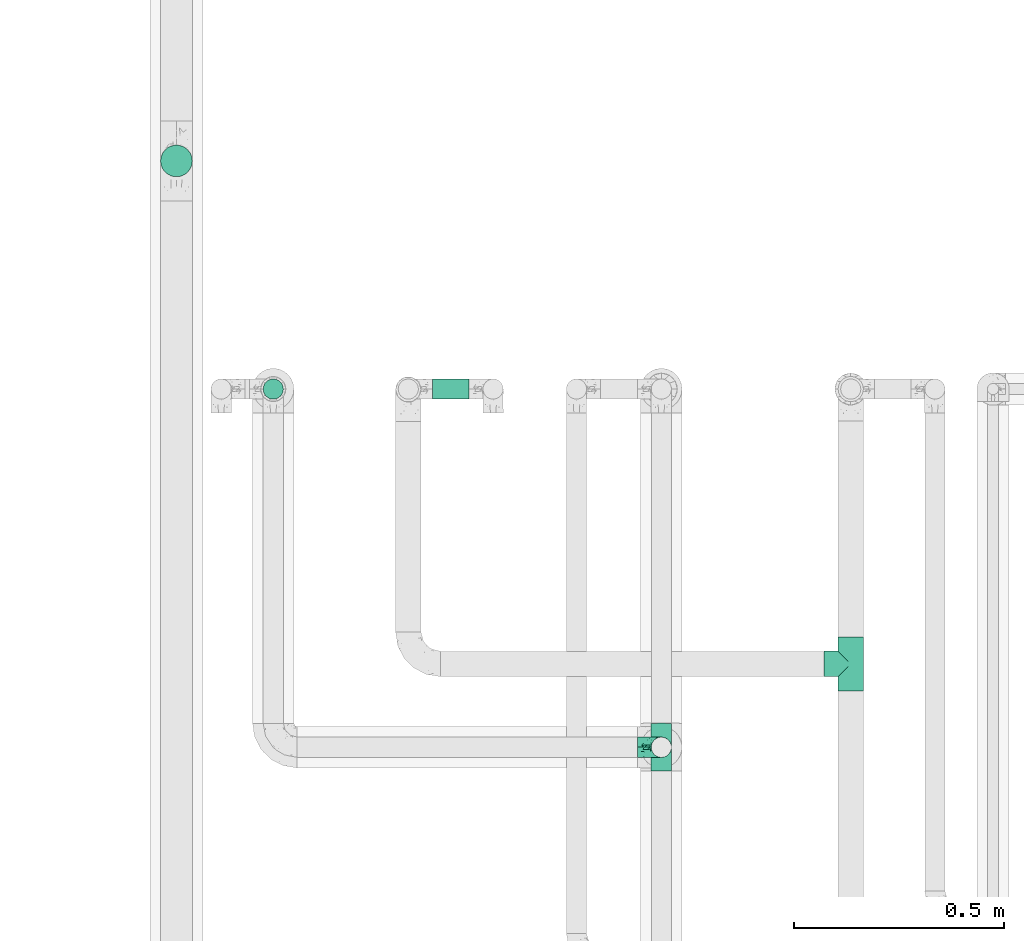
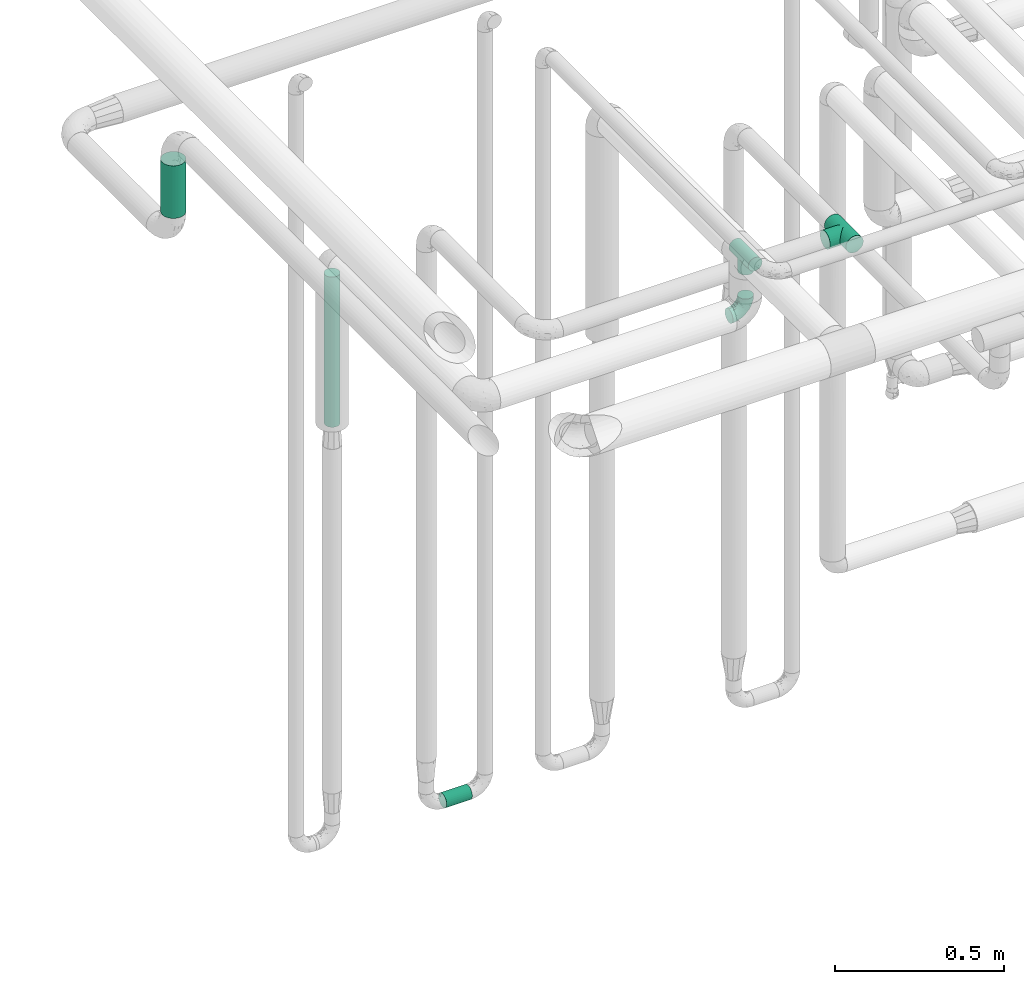
# One storey, part 696 of 827: 3 flow fittings, 3 flow segments.
"""IFC2X3 building model written with IfcOpenShell, lengths in millimetres."""

from ifc_helpers import new_model, entity, si_unit, converted_unit, derived_unit, direction, frame, origin, origin_2d_with_axis, place, context, subcontext, project, spatial, circle, extrude, faceted_brep, source, transform, mapped, material, type_object, type_shapes, element, save


model = new_model("IFC2X3")

# Units and contexts
model_context = context("Model", 3, precision=0.01, world=origin(), true_north=direction((6.12303176911189e-17, 1.0)))
body_context = subcontext(model_context, "Body", "Model", "MODEL_VIEW")
ifc_project = project(units=[si_unit("LENGTHUNIT", "METRE", prefix="MILLI"), si_unit("AREAUNIT", "SQUARE_METRE"), si_unit("VOLUMEUNIT", "CUBIC_METRE"), converted_unit("PLANEANGLEUNIT", "DEGREE", entity("IfcRatioMeasure", 0.0174532925199433), si_unit("PLANEANGLEUNIT", "RADIAN"), dimensions=[0, 0, 0, 0, 0, 0, 0]), si_unit("MASSUNIT", "GRAM", prefix="KILO"), derived_unit("MASSDENSITYUNIT", [(si_unit("MASSUNIT", "GRAM", prefix="KILO"), 1), (si_unit("LENGTHUNIT", "METRE"), -3)]), derived_unit("MOMENTOFINERTIAUNIT", [(si_unit("LENGTHUNIT", "METRE"), 4)]), si_unit("TIMEUNIT", "SECOND"), si_unit("FREQUENCYUNIT", "HERTZ"), si_unit("THERMODYNAMICTEMPERATUREUNIT", "DEGREE_CELSIUS"), derived_unit("THERMALTRANSMITTANCEUNIT", [(si_unit("MASSUNIT", "GRAM", prefix="KILO"), 1), (si_unit("THERMODYNAMICTEMPERATUREUNIT", "KELVIN"), -1), (si_unit("TIMEUNIT", "SECOND"), -3)]), derived_unit("VOLUMETRICFLOWRATEUNIT", [(si_unit("LENGTHUNIT", "METRE"), 3), (si_unit("TIMEUNIT", "SECOND"), -1)]), derived_unit("MASSFLOWRATEUNIT", [(si_unit("MASSUNIT", "GRAM", prefix="KILO"), 1), (si_unit("TIMEUNIT", "SECOND"), -1)]), derived_unit("ROTATIONALFREQUENCYUNIT", [(si_unit("TIMEUNIT", "SECOND"), -1)]), si_unit("ELECTRICCURRENTUNIT", "AMPERE"), si_unit("ELECTRICVOLTAGEUNIT", "VOLT"), si_unit("POWERUNIT", "WATT"), si_unit("FORCEUNIT", "NEWTON", prefix="KILO"), si_unit("ILLUMINANCEUNIT", "LUX"), si_unit("LUMINOUSFLUXUNIT", "LUMEN"), si_unit("LUMINOUSINTENSITYUNIT", "CANDELA"), derived_unit("USERDEFINED", [(si_unit("MASSUNIT", "GRAM", prefix="KILO"), -1), (si_unit("LENGTHUNIT", "METRE"), -2), (si_unit("TIMEUNIT", "SECOND"), 3), (si_unit("LUMINOUSFLUXUNIT", "LUMEN"), 1)]), derived_unit("LINEARVELOCITYUNIT", [(si_unit("LENGTHUNIT", "METRE"), 1), (si_unit("TIMEUNIT", "SECOND"), -1)]), si_unit("PRESSUREUNIT", "PASCAL"), derived_unit("USERDEFINED", [(si_unit("LENGTHUNIT", "METRE"), -2), (si_unit("MASSUNIT", "GRAM", prefix="KILO"), 1), (si_unit("TIMEUNIT", "SECOND"), -2)]), derived_unit("LINEARFORCEUNIT", [(si_unit("MASSUNIT", "GRAM", prefix="KILO"), 1), (si_unit("LENGTHUNIT", "METRE"), 1), (si_unit("TIMEUNIT", "SECOND"), -2), (si_unit("LENGTHUNIT", "METRE"), -1)]), derived_unit("PLANARFORCEUNIT", [(si_unit("MASSUNIT", "GRAM", prefix="KILO"), 1), (si_unit("LENGTHUNIT", "METRE"), 1), (si_unit("TIMEUNIT", "SECOND"), -2), (si_unit("LENGTHUNIT", "METRE"), -2)])], contexts=[model_context])

# Site, building, storey
site_placement = place(None, origin())
site = spatial("IfcSite", under=ifc_project, at=site_placement, CompositionType="ELEMENT")
building_placement = place(site_placement, origin())
building = spatial("IfcBuilding", under=site, at=building_placement, CompositionType="ELEMENT")
storey_placement = place(building_placement, frame((0.0, 0.0, 28200.0)))
storey = spatial("IfcBuildingStorey", under=building, at=storey_placement, Name="08", CompositionType="ELEMENT", Elevation=28200.0)

# Flow segments
pipe_segment_type = type_object("IfcPipeSegmentType", PredefinedType="NOTDEFINED")
flow_segment_1_placement = place(storey_placement, frame((51928.76, 18003.03, 2415.0)))
element("IfcFlowSegment", 1, at=flow_segment_1_placement, inside=storey, type_object=pipe_segment_type, context=body_context, shape_type="SweptSolid", body=[
    extrude(circle(Radius=37.75, at=origin_2d_with_axis()), frame((39.35, 39.35, 0.0)), (0.0, 0.0, 1.0), 190.000000000004),
])
flow_segment_2_placement = place(storey_placement, frame((52576.38, 17474.4, 374.4)))
element("IfcFlowSegment", 2, at=flow_segment_2_placement, inside=storey, type_object=pipe_segment_type, context=body_context, shape_type="SweptSolid", body=[
    extrude(circle(Radius=24.0, at=origin_2d_with_axis()), frame((0.0, 25.6, 25.6), z_axis=(1.0, 0.0, 0.0), x_axis=(0.0, 1.0, 0.0)), (0.0, 0.0, 1.0), 87.6742700000116),
])
flow_segment_3_placement = place(storey_placement, frame((52172.68, 17474.4, 1898.17)))
element("IfcFlowSegment", 3, at=flow_segment_3_placement, inside=storey, type_object=pipe_segment_type, context=body_context, shape_type="SweptSolid", body=[
    extrude(circle(Radius=24.0, at=origin_2d_with_axis()), frame((25.6, 25.6, 0.0)), (0.0, 0.0, 1.0), 543.000000000011),
])

# Flow fittings
ifc_material = material()
pipe_fitting_type_1 = type_object("IfcPipeFittingType", Name="ADSK_1", PredefinedType="NOTDEFINED", material=ifc_material)
shared_shape_1 = source(origin(), body_context, "Body", "Brep", [
    faceted_brep([(-57.0, 12.07, -20.91), (-57.0, 6.25, -23.33), (-57.0, 0.0, -24.15), (-57.0, -6.25, -23.33), (-57.0, -12.08, -20.91), (-57.0, -17.08, -17.08), (-57.0, -20.91, -12.08), (-57.0, -23.33, -6.25), (-57.0, -24.15, 0.0), (-57.0, -23.33, 6.25), (-57.0, -20.91, 12.07), (-57.0, -17.08, 17.08), (-57.0, -12.08, 20.91), (-57.0, -6.25, 23.33), (-57.0, 0.0, 24.15), (-57.0, 6.25, 23.33), (-57.0, 12.07, 20.91), (-57.0, 17.08, 17.08), (-57.0, 20.91, 12.07), (-57.0, 23.33, 6.25), (-57.0, 24.15, 0.0), (-57.0, 23.33, -6.25), (-57.0, 20.91, -12.08), (-57.0, 17.08, -17.08), (0.0, 57.0, -24.15), (-6.25, 57.0, -23.33), (-12.07, 57.0, -20.91), (-17.08, 57.0, -17.08), (-20.91, 57.0, -12.08), (-23.33, 57.0, -6.25), (-24.15, 57.0, 0.0), (-23.33, 57.0, 6.25), (-20.91, 57.0, 12.07), (-17.08, 57.0, 17.08), (-12.07, 57.0, 20.91), (-6.25, 57.0, 23.33), (0.0, 57.0, 24.15), (6.25, 57.0, 23.33), (12.08, 57.0, 20.91), (17.08, 57.0, 17.08), (20.91, 57.0, 12.07), (23.33, 57.0, 6.25), (24.15, 57.0, 0.0), (23.33, 57.0, -6.25), (20.91, 57.0, -12.08), (17.08, 57.0, -17.08), (12.08, 57.0, -20.91), (6.25, 57.0, -23.33), (14.9, 21.14, 6.17), (13.61, 24.64, 12.48), (6.23, 8.95, 8.98), (-41.47, -21.06, 0.0), (-41.92, -18.38, 13.72), (-24.64, -13.61, 12.48), (-37.37, -13.24, 18.15), (-6.8, -4.93, 8.18), (-21.76, -15.19, 6.22), (-12.78, -9.18, 0.0), (-37.73, -20.51, 7.75), (-7.38, 7.38, 20.24), (-23.37, -4.26, 20.42), (-11.9, -3.19, 15.86), (-42.14, -8.7, 21.82), (13.24, 37.37, 18.15), (9.33, 23.53, 16.85), (4.26, 23.37, 20.42), (2.77, 10.92, 15.55), (-29.46, 0.91, 23.52), (-44.13, 20.56, 15.69), (-39.25, 26.33, 10.88), (-49.02, 22.92, 9.96), (-34.58, 23.87, 17.15), (-15.8, 6.8, 22.81), (-8.67, 20.47, 23.88), (-18.12, 12.9, 24.08), (-48.29, 14.92, 19.65), (-44.06, -2.85, 23.78), (-9.23, 48.95, 22.58), (-3.78, 42.74, 24.07), (-40.34, 4.26, 24.09), (-44.02, 26.14, 5.46), (-44.04, 9.88, 22.74), (-4.95, 16.87, 22.52), (-2.75, 1.43, 12.5), (-25.48, 40.98, 10.71), (20.51, 37.73, 7.75), (18.38, 41.92, 13.72), (8.7, 42.14, 21.82), (-25.95, -17.97, 0.0), (2.85, 44.06, 23.78), (21.06, 41.47, 0.0), (17.97, 25.95, 0.0), (-24.04, -9.27, 17.13), (-33.26, 33.26, 5.86), (-28.55, 40.57, 0.0), (-40.57, 28.55, 0.0), (-25.29, 47.19, 4.06), (-27.01, 31.1, 16.77), (-15.7, 43.95, 19.9), (-20.27, 45.22, 15.61), (-30.53, 31.98, 12.64), (-11.28, 38.33, 22.92), (-9.97, 27.88, 24.09), (-20.15, 30.26, 21.25), (-31.25, 11.75, 23.64), (-28.75, 7.23, 24.15), (-29.53, 18.06, 22.27), (-28.44, 24.21, 20.02), (-37.55, 17.7, 20.26), (-15.88, 29.25, 22.99), (-20.82, 20.82, 23.44), (-0.91, 29.46, 23.52), (-13.5, -7.67, 12.04), (1.49, 1.56, 5.16), (8.86, 10.35, 4.59), (0.38, -0.38, 0.0), (9.18, 12.78, 0.0), (-37.37, -13.24, -18.15), (8.86, 10.35, -4.59), (-45.22, 20.27, -15.61), (-43.95, 15.7, -19.9), (-38.33, 11.28, -22.92), (-48.95, 9.23, -22.58), (-47.19, 25.29, -4.06), (-33.26, 33.26, -5.86), (18.38, 41.92, -13.72), (-30.26, 20.15, -21.25), (2.85, 44.06, -23.78), (-4.26, 40.34, -24.09), (-40.98, 25.48, -10.71), (-41.92, -18.38, -13.72), (9.25, 23.5, -16.92), (4.26, 23.37, -20.42), (13.24, 37.37, -18.15), (-37.73, -20.51, -7.75), (-11.75, 31.25, -23.64), (-7.23, 28.75, -24.15), (-12.9, 18.12, -24.08), (8.7, 42.14, -21.82), (-44.06, -2.85, -23.78), (-6.8, 15.8, -22.81), (-20.47, 8.67, -23.88), (-24.64, -13.61, -12.48), (-42.74, 3.78, -24.07), (-18.06, 29.53, -22.27), (-24.21, 28.44, -20.02), (-27.88, 9.97, -24.09), (-31.1, 27.01, -16.77), (-26.14, 44.02, -5.46), (14.9, 21.14, -6.17), (20.51, 37.73, -7.75), (-9.88, 44.04, -22.74), (-20.56, 44.13, -15.69), (-21.76, -15.19, -6.22), (-13.5, -7.67, -12.04), (-24.14, -9.76, -16.74), (-11.9, -3.19, -15.86), (-14.92, 48.29, -19.65), (-23.37, -4.26, -20.42), (-0.91, 29.46, -23.52), (-26.33, 39.25, -10.88), (-23.87, 34.58, -17.15), (-42.14, -8.7, -21.82), (-22.92, 49.02, -9.96), (13.61, 24.64, -12.48), (-31.98, 30.53, -12.64), (-16.87, 4.95, -22.52), (-17.7, 37.55, -20.26), (-29.25, 15.88, -22.99), (-20.82, 20.82, -23.44), (-29.46, 0.91, -23.52), (-7.38, 7.38, -20.24), (2.77, 10.92, -15.55), (6.23, 8.95, -8.98), (-6.8, -4.93, -8.18), (-2.81, 1.41, -12.54), (1.49, 1.56, -5.16)], [[[0, 1, 2, 3, 4, 5, 6, 7, 8, 9, 10, 11, 12, 13, 14, 15, 16, 17, 18, 19, 20, 21, 22, 23]], [[24, 25, 26, 27, 28, 29, 30, 31, 32, 33, 34, 35, 36, 37, 38, 39, 40, 41, 42, 43, 44, 45, 46, 47]], [[48, 49, 50]], [[9, 8, 51]], [[52, 53, 54]], [[55, 56, 57]], [[10, 58, 52]], [[9, 58, 10]], [[59, 60, 61]], [[54, 12, 11]], [[54, 62, 12]], [[63, 39, 38]], [[64, 65, 66]], [[62, 60, 67]], [[68, 69, 70]], [[71, 69, 68]], [[72, 73, 74]], [[16, 75, 17]], [[13, 76, 14]], [[35, 77, 78]], [[14, 79, 15]], [[17, 68, 18]], [[14, 76, 79]], [[20, 19, 80]], [[70, 19, 18]], [[81, 15, 79]], [[15, 81, 16]], [[73, 72, 82]], [[66, 83, 50]], [[32, 31, 84]], [[85, 86, 49]], [[63, 87, 65]], [[56, 58, 88]], [[36, 89, 37]], [[85, 41, 40]], [[36, 35, 78]], [[90, 41, 85]], [[40, 39, 86]], [[12, 62, 13]], [[86, 85, 40]], [[48, 85, 49]], [[85, 91, 90]], [[87, 38, 37]], [[92, 60, 54]], [[80, 69, 93]], [[93, 94, 95]], [[10, 52, 11]], [[94, 96, 30]], [[97, 98, 99]], [[80, 93, 95]], [[100, 97, 84]], [[99, 98, 33]], [[101, 102, 78]], [[103, 101, 98]], [[96, 31, 30]], [[77, 98, 101]], [[77, 35, 34]], [[34, 33, 98]], [[9, 51, 58]], [[87, 63, 38]], [[104, 105, 74]], [[106, 103, 107]], [[106, 81, 104]], [[75, 68, 17]], [[108, 107, 71]], [[33, 32, 99]], [[109, 103, 110]], [[101, 109, 102]], [[89, 78, 111]], [[53, 52, 58]], [[54, 11, 52]], [[60, 62, 54]], [[88, 58, 51]], [[76, 62, 67]], [[53, 112, 92]], [[60, 59, 72]], [[39, 63, 86]], [[49, 86, 63]], [[89, 87, 37]], [[42, 41, 90]], [[111, 82, 65]], [[111, 65, 87]], [[65, 59, 66]], [[104, 81, 79]], [[75, 81, 108]], [[32, 84, 99]], [[97, 99, 84]], [[98, 97, 103]], [[106, 107, 108]], [[74, 102, 110]], [[111, 78, 102]], [[74, 110, 104]], [[74, 67, 72]], [[61, 92, 112]], [[66, 59, 61]], [[56, 53, 58]], [[66, 50, 49]], [[61, 112, 83]], [[66, 49, 64]], [[78, 89, 36]], [[87, 89, 111]], [[62, 76, 13]], [[79, 76, 67]], [[100, 93, 69]], [[96, 93, 84]], [[55, 113, 50]], [[113, 114, 50]], [[104, 79, 105]], [[106, 104, 110]], [[20, 80, 95]], [[85, 48, 91]], [[115, 114, 113]], [[116, 91, 48]], [[70, 80, 19]], [[93, 96, 94]], [[84, 31, 96]], [[103, 106, 110]], [[81, 106, 108]], [[103, 97, 107]], [[71, 107, 97]], [[71, 97, 100]], [[108, 71, 68]], [[79, 67, 105]], [[67, 74, 105]], [[115, 113, 57]], [[112, 56, 55]], [[56, 88, 57]], [[60, 72, 67]], [[82, 72, 59]], [[65, 82, 59]], [[82, 111, 73]], [[111, 102, 73]], [[102, 74, 73]], [[81, 75, 16]], [[68, 75, 108]], [[68, 70, 18]], [[80, 70, 69]], [[98, 77, 34]], [[78, 77, 101]], [[93, 100, 84]], [[71, 100, 69]], [[102, 109, 110]], [[101, 103, 109]], [[53, 92, 54]], [[61, 60, 92]], [[56, 112, 53]], [[83, 112, 55]], [[50, 83, 55]], [[61, 83, 66]], [[49, 63, 64]], [[65, 64, 63]], [[57, 113, 55]], [[114, 115, 116]], [[116, 48, 114]], [[48, 50, 114]], [[117, 5, 4]], [[116, 115, 118]], [[119, 120, 23]], [[121, 122, 120]], [[95, 123, 20]], [[0, 23, 120]], [[124, 95, 94]], [[125, 45, 44]], [[121, 120, 126]], [[24, 127, 128]], [[22, 21, 129]], [[0, 122, 1]], [[5, 117, 130]], [[131, 132, 133]], [[134, 88, 51]], [[135, 136, 137]], [[6, 5, 130]], [[46, 138, 47]], [[139, 3, 2]], [[140, 141, 137]], [[6, 134, 7]], [[134, 130, 142]], [[143, 2, 1]], [[144, 126, 145]], [[121, 146, 143]], [[147, 120, 119]], [[94, 148, 124]], [[149, 150, 91]], [[30, 29, 148]], [[151, 25, 128]], [[27, 152, 28]], [[134, 153, 88]], [[154, 155, 156]], [[27, 26, 157]], [[151, 26, 25]], [[155, 158, 156]], [[24, 47, 127]], [[1, 122, 143]], [[138, 132, 159]], [[160, 152, 161]], [[24, 128, 25]], [[46, 133, 138]], [[162, 117, 4]], [[148, 160, 124]], [[152, 160, 163]], [[154, 142, 155]], [[45, 125, 133]], [[133, 46, 45]], [[125, 164, 133]], [[51, 7, 134]], [[42, 90, 43]], [[165, 147, 129]], [[153, 134, 142]], [[43, 150, 44]], [[162, 4, 3]], [[141, 140, 166]], [[117, 162, 158]], [[163, 29, 28]], [[43, 90, 150]], [[123, 21, 20]], [[144, 151, 135]], [[157, 152, 27]], [[167, 145, 161]], [[23, 22, 119]], [[168, 126, 169]], [[121, 168, 146]], [[139, 143, 170]], [[142, 130, 117]], [[8, 7, 51]], [[134, 6, 130]], [[139, 162, 3]], [[170, 166, 158]], [[170, 158, 162]], [[158, 171, 156]], [[44, 150, 125]], [[91, 150, 90]], [[164, 125, 150]], [[132, 138, 133]], [[127, 138, 159]], [[131, 164, 172]], [[132, 171, 140]], [[135, 151, 128]], [[157, 151, 167]], [[22, 129, 119]], [[147, 119, 129]], [[120, 147, 126]], [[144, 145, 167]], [[137, 146, 169]], [[170, 143, 146]], [[137, 169, 135]], [[137, 159, 140]], [[171, 172, 156]], [[173, 174, 175]], [[156, 175, 154]], [[174, 57, 153]], [[132, 172, 171]], [[172, 164, 173]], [[143, 139, 2]], [[162, 139, 170]], [[138, 127, 47]], [[128, 127, 159]], [[165, 124, 160]], [[123, 124, 129]], [[149, 173, 164]], [[176, 174, 173]], [[135, 128, 136]], [[144, 135, 169]], [[150, 149, 164]], [[176, 118, 115]], [[149, 91, 116]], [[30, 148, 94]], [[163, 148, 29]], [[124, 123, 95]], [[129, 21, 123]], [[126, 144, 169]], [[151, 144, 167]], [[126, 147, 145]], [[161, 145, 147]], [[161, 147, 165]], [[167, 161, 152]], [[128, 159, 136]], [[159, 137, 136]], [[154, 153, 142]], [[132, 140, 159]], [[174, 176, 57]], [[57, 88, 153]], [[166, 140, 171]], [[158, 166, 171]], [[166, 170, 141]], [[170, 146, 141]], [[146, 137, 141]], [[151, 157, 26]], [[152, 157, 167]], [[152, 163, 28]], [[148, 163, 160]], [[120, 122, 0]], [[143, 122, 121]], [[124, 165, 129]], [[161, 165, 160]], [[146, 168, 169]], [[121, 126, 168]], [[142, 117, 155]], [[158, 155, 117]], [[175, 156, 172]], [[153, 154, 174]], [[173, 175, 172]], [[174, 154, 175]], [[164, 131, 133]], [[172, 132, 131]], [[176, 173, 118]], [[57, 176, 115]], [[173, 149, 118]], [[149, 116, 118]]]),
])
type_shapes(pipe_fitting_type_1, [shared_shape_1])
flow_fitting_1_placement = place(storey_placement, frame((53121.06, 16648.39, 2498.17), z_axis=(0.0, 0.999999852624976, 0.000542908855839149), x_axis=(0.0, 0.000542908855839149, -0.999999852624976)))
element("IfcFlowFitting", 4, at=flow_fitting_1_placement, inside=storey, type_object=pipe_fitting_type_1, material=ifc_material, Name="ADSK_1", ObjectType="ADSK_1", context=body_context, shape_type="MappedRepresentation", body=[
    mapped(shared_shape_1, transform((0.0, 0.0, 0.0), scale=1.0)),
])
pipe_fitting_type_2 = type_object("IfcPipeFittingType", Name="ADSK_1", PredefinedType="NOTDEFINED", material=ifc_material)
shared_shape_2 = source(origin(), body_context, "Body", "Brep", [
    faceted_brep([(-57.0, 12.07, -20.91), (-57.0, 6.25, -23.33), (-57.0, 0.0, -24.15), (-57.0, -6.25, -23.33), (-57.0, -12.08, -20.91), (-57.0, -17.08, -17.08), (-57.0, -20.91, -12.08), (-57.0, -23.33, -6.25), (-57.0, -24.15, 0.0), (-57.0, -23.33, 6.25), (-57.0, -20.91, 12.07), (-57.0, -17.08, 17.08), (-57.0, -12.08, 20.91), (-57.0, -6.25, 23.33), (-57.0, 0.0, 24.15), (-57.0, 6.25, 23.33), (-57.0, 12.07, 20.91), (-57.0, 17.08, 17.08), (-57.0, 20.91, 12.07), (-57.0, 23.33, 6.25), (-57.0, 24.15, 0.0), (-57.0, 23.33, -6.25), (-57.0, 20.91, -12.08), (-57.0, 17.08, -17.08), (57.0, 0.0, -24.15), (57.0, 6.25, -23.33), (57.0, 12.07, -20.91), (57.0, 17.08, -17.08), (57.0, 20.91, -12.08), (57.0, 23.33, -6.25), (57.0, 24.15, 0.0), (57.0, 23.33, 6.25), (57.0, 20.91, 12.07), (57.0, 17.08, 17.08), (57.0, 12.07, 20.91), (57.0, 6.25, 23.33), (57.0, 0.0, 24.15), (57.0, -6.25, 23.33), (57.0, -12.08, 20.91), (57.0, -17.08, 17.08), (57.0, -20.91, 12.07), (57.0, -23.33, 6.25), (57.0, -24.15, 0.0), (57.0, -23.33, -6.25), (57.0, -20.91, -12.08), (57.0, -17.08, -17.08), (57.0, -12.08, -20.91), (57.0, -6.25, -23.33), (23.27, -23.27, 6.45), (24.15, -24.15, 0.0), (-24.15, -24.15, 0.0), (20.9, -20.9, 12.1), (13.54, -13.54, 20.0), (17.52, -17.52, 16.62), (-23.27, -23.27, 6.45), (-20.9, -20.9, 12.1), (-17.52, -17.52, 16.62), (-13.54, -13.54, 20.0), (-9.19, -9.19, 22.33), (9.19, -9.19, 22.33), (4.64, -4.64, 23.7), (0.0, 0.0, 24.15), (-4.64, -4.64, 23.7), (4.64, -4.64, -23.7), (0.0, 0.0, -24.15), (-4.64, -4.64, -23.7), (-9.19, -9.19, -22.33), (9.19, -9.19, -22.33), (13.54, -13.54, -20.0), (17.52, -17.52, -16.62), (20.9, -20.9, -12.1), (23.27, -23.27, -6.45), (-13.54, -13.54, -20.0), (-17.52, -17.52, -16.62), (-23.27, -23.27, -6.45), (-20.9, -20.9, -12.1), (0.0, -57.0, -24.15), (6.25, -57.0, -23.33), (12.08, -57.0, -20.91), (17.08, -57.0, -17.08), (20.91, -57.0, -12.08), (23.33, -57.0, -6.25), (24.15, -57.0, 0.0), (23.33, -57.0, 6.25), (20.91, -57.0, 12.07), (17.08, -57.0, 17.08), (12.08, -57.0, 20.91), (6.25, -57.0, 23.33), (0.0, -57.0, 24.15), (-6.25, -57.0, 23.33), (-12.07, -57.0, 20.91), (-17.08, -57.0, 17.08), (-20.91, -57.0, 12.07), (-23.33, -57.0, 6.25), (-24.15, -57.0, 0.0), (-23.33, -57.0, -6.25), (-20.91, -57.0, -12.08), (-17.08, -57.0, -17.08), (-12.07, -57.0, -20.91), (-6.25, -57.0, -23.33)], [[[0, 1, 2, 3, 4, 5, 6, 7, 8, 9, 10, 11, 12, 13, 14, 15, 16, 17, 18, 19, 20, 21, 22, 23]], [[24, 25, 26, 27, 28, 29, 30, 31, 32, 33, 34, 35, 36, 37, 38, 39, 40, 41, 42, 43, 44, 45, 46, 47]], [[41, 40, 48]], [[42, 41, 49]], [[50, 9, 8]], [[49, 41, 48]], [[40, 51, 48]], [[39, 38, 52]], [[51, 40, 53]], [[52, 53, 39]], [[53, 40, 39]], [[50, 54, 9]], [[9, 54, 10]], [[54, 55, 10]], [[56, 57, 11]], [[11, 10, 56]], [[11, 57, 12]], [[56, 10, 55]], [[12, 57, 58]], [[52, 38, 59]], [[60, 36, 61]], [[62, 61, 14]], [[59, 37, 60]], [[37, 59, 38]], [[60, 37, 36]], [[61, 36, 35, 15, 14]], [[32, 31, 19, 18]], [[17, 16, 34, 33]], [[18, 17, 33, 32]], [[35, 34, 16, 15]], [[20, 19, 31, 30]], [[62, 13, 58]], [[13, 62, 14]], [[58, 13, 12]], [[27, 23, 22, 28]], [[22, 21, 29, 28]], [[0, 23, 27, 26]], [[20, 30, 29, 21]], [[24, 47, 63]], [[24, 64, 2, 1, 25]], [[64, 24, 63]], [[2, 64, 65]], [[26, 25, 1, 0]], [[65, 66, 3]], [[2, 65, 3]], [[66, 4, 3]], [[63, 47, 67]], [[46, 45, 68]], [[69, 68, 45]], [[44, 70, 69]], [[69, 45, 44]], [[46, 68, 67]], [[43, 42, 49]], [[7, 50, 8]], [[43, 71, 44]], [[71, 43, 49]], [[44, 71, 70]], [[72, 4, 66]], [[72, 5, 4]], [[5, 72, 73]], [[5, 73, 6]], [[74, 50, 7]], [[75, 74, 6]], [[74, 7, 6]], [[75, 6, 73]], [[46, 67, 47]], [[76, 77, 78, 79, 80, 81, 82, 83, 84, 85, 86, 87, 88, 89, 90, 91, 92, 93, 94, 95, 96, 97, 98, 99]], [[50, 94, 93]], [[54, 50, 93]], [[91, 90, 57]], [[56, 92, 91]], [[54, 93, 92]], [[58, 90, 89]], [[55, 54, 92]], [[56, 55, 92]], [[58, 57, 90]], [[88, 61, 62]], [[58, 89, 62]], [[56, 91, 57]], [[62, 89, 88]], [[60, 88, 87]], [[86, 59, 87]], [[84, 83, 48]], [[53, 85, 84]], [[52, 86, 85]], [[49, 83, 82]], [[59, 60, 87]], [[52, 59, 86]], [[49, 48, 83]], [[51, 53, 84]], [[48, 51, 84]], [[52, 85, 53]], [[88, 60, 61]], [[82, 81, 49]], [[71, 49, 81]], [[69, 80, 79]], [[79, 78, 68]], [[71, 81, 80]], [[67, 78, 77]], [[70, 71, 80]], [[69, 70, 80]], [[67, 68, 78]], [[76, 64, 63]], [[67, 77, 63]], [[69, 79, 68]], [[63, 77, 76]], [[65, 76, 99]], [[98, 66, 99]], [[96, 95, 74]], [[73, 97, 96]], [[72, 98, 97]], [[50, 95, 94]], [[66, 65, 99]], [[72, 66, 98]], [[50, 74, 95]], [[75, 73, 96]], [[74, 75, 96]], [[72, 97, 73]], [[76, 65, 64]]]),
])
type_shapes(pipe_fitting_type_2, [shared_shape_2])
flow_fitting_2_placement = place(storey_placement, frame((53121.06, 16648.39, 2699.3), z_axis=(-1.0, 0.0, 0.0), x_axis=(0.0, -0.999999057686602, 0.00137281677840057)))
element("IfcFlowFitting", 5, at=flow_fitting_2_placement, inside=storey, type_object=pipe_fitting_type_2, material=ifc_material, Name="ADSK_1", ObjectType="ADSK_1", context=body_context, shape_type="MappedRepresentation", body=[
    mapped(shared_shape_2, transform((0.0, 0.0, 0.0), scale=1.0)),
])
pipe_fitting_type_3 = type_object("IfcPipeFittingType", Name="ADSK_1", PredefinedType="NOTDEFINED", material=ifc_material)
shared_shape_3 = source(origin(), body_context, "Body", "Brep", [
    faceted_brep([(-64.0, 15.07, -26.11), (-64.0, 7.8, -29.12), (-64.0, 0.0, -30.15), (-64.0, -7.8, -29.12), (-64.0, -15.08, -26.11), (-64.0, -21.32, -21.32), (-64.0, -26.11, -15.08), (-64.0, -29.12, -7.8), (-64.0, -30.15, 0.0), (-64.0, -29.12, 7.8), (-64.0, -26.11, 15.07), (-64.0, -21.32, 21.32), (-64.0, -15.08, 26.11), (-64.0, -7.8, 29.12), (-64.0, 0.0, 30.15), (-64.0, 7.8, 29.12), (-64.0, 15.07, 26.11), (-64.0, 21.32, 21.32), (-64.0, 26.11, 15.07), (-64.0, 29.12, 7.8), (-64.0, 30.15, 0.0), (-64.0, 29.12, -7.8), (-64.0, 26.11, -15.08), (-64.0, 21.32, -21.32), (64.0, 0.0, -30.15), (64.0, 7.8, -29.12), (64.0, 15.07, -26.11), (64.0, 21.32, -21.32), (64.0, 26.11, -15.08), (64.0, 29.12, -7.8), (64.0, 30.15, 0.0), (64.0, 29.12, 7.8), (64.0, 26.11, 15.07), (64.0, 21.32, 21.32), (64.0, 15.07, 26.11), (64.0, 7.8, 29.12), (64.0, 0.0, 30.15), (64.0, -7.8, 29.12), (64.0, -15.08, 26.11), (64.0, -21.32, 21.32), (64.0, -26.11, 15.07), (64.0, -29.12, 7.8), (64.0, -30.15, 0.0), (64.0, -29.12, -7.8), (64.0, -26.11, -15.08), (64.0, -21.32, -21.32), (64.0, -15.08, -26.11), (64.0, -7.8, -29.12), (29.06, -29.06, 8.05), (30.15, -30.15, 0.0), (-30.15, -30.15, 0.0), (26.09, -26.09, 15.1), (16.9, -16.9, 24.97), (21.88, -21.88, 20.75), (-29.06, -29.06, 8.05), (-26.09, -26.09, 15.1), (-21.88, -21.88, 20.75), (-16.9, -16.9, 24.97), (-11.47, -11.47, 27.88), (11.47, -11.47, 27.88), (5.79, -5.79, 29.59), (0.0, 0.0, 30.15), (-5.79, -5.79, 29.59), (5.79, -5.79, -29.59), (0.0, 0.0, -30.15), (-5.79, -5.79, -29.59), (-11.47, -11.47, -27.88), (11.47, -11.47, -27.88), (16.9, -16.9, -24.97), (21.88, -21.88, -20.75), (26.09, -26.09, -15.1), (29.06, -29.06, -8.05), (-16.9, -16.9, -24.97), (-21.88, -21.88, -20.75), (-29.06, -29.06, -8.05), (-26.09, -26.09, -15.1), (0.0, -64.0, -30.15), (7.8, -64.0, -29.12), (15.08, -64.0, -26.11), (21.32, -64.0, -21.32), (26.11, -64.0, -15.08), (29.12, -64.0, -7.8), (30.15, -64.0, 0.0), (29.12, -64.0, 7.8), (26.11, -64.0, 15.07), (21.32, -64.0, 21.32), (15.08, -64.0, 26.11), (7.8, -64.0, 29.12), (0.0, -64.0, 30.15), (-7.8, -64.0, 29.12), (-15.07, -64.0, 26.11), (-21.32, -64.0, 21.32), (-26.11, -64.0, 15.07), (-29.12, -64.0, 7.8), (-30.15, -64.0, 0.0), (-29.12, -64.0, -7.8), (-26.11, -64.0, -15.08), (-21.32, -64.0, -21.32), (-15.07, -64.0, -26.11), (-7.8, -64.0, -29.12)], [[[0, 1, 2, 3, 4, 5, 6, 7, 8, 9, 10, 11, 12, 13, 14, 15, 16, 17, 18, 19, 20, 21, 22, 23]], [[24, 25, 26, 27, 28, 29, 30, 31, 32, 33, 34, 35, 36, 37, 38, 39, 40, 41, 42, 43, 44, 45, 46, 47]], [[41, 40, 48]], [[42, 41, 49]], [[50, 9, 8]], [[49, 41, 48]], [[40, 51, 48]], [[39, 38, 52]], [[51, 40, 53]], [[52, 53, 39]], [[53, 40, 39]], [[50, 54, 9]], [[9, 54, 10]], [[54, 55, 10]], [[56, 57, 11]], [[11, 10, 56]], [[11, 57, 12]], [[56, 10, 55]], [[12, 57, 58]], [[52, 38, 59]], [[60, 36, 61]], [[62, 61, 14]], [[59, 37, 60]], [[37, 59, 38]], [[60, 37, 36]], [[61, 36, 35, 15, 14]], [[32, 31, 19, 18]], [[17, 16, 34, 33]], [[18, 17, 33, 32]], [[35, 34, 16, 15]], [[20, 19, 31, 30]], [[62, 13, 58]], [[13, 62, 14]], [[58, 13, 12]], [[27, 23, 22, 28]], [[22, 21, 29, 28]], [[0, 23, 27, 26]], [[20, 30, 29, 21]], [[24, 47, 63]], [[24, 64, 2, 1, 25]], [[64, 24, 63]], [[2, 64, 65]], [[26, 25, 1, 0]], [[65, 66, 3]], [[2, 65, 3]], [[66, 4, 3]], [[63, 47, 67]], [[46, 45, 68]], [[69, 68, 45]], [[44, 70, 69]], [[69, 45, 44]], [[46, 68, 67]], [[43, 42, 49]], [[7, 50, 8]], [[43, 71, 44]], [[71, 43, 49]], [[44, 71, 70]], [[72, 4, 66]], [[72, 5, 4]], [[5, 72, 73]], [[5, 73, 6]], [[74, 50, 7]], [[75, 74, 6]], [[74, 7, 6]], [[75, 6, 73]], [[46, 67, 47]], [[76, 77, 78, 79, 80, 81, 82, 83, 84, 85, 86, 87, 88, 89, 90, 91, 92, 93, 94, 95, 96, 97, 98, 99]], [[50, 94, 93]], [[54, 50, 93]], [[91, 90, 57]], [[56, 92, 91]], [[54, 93, 92]], [[58, 90, 89]], [[55, 54, 92]], [[56, 55, 92]], [[58, 57, 90]], [[88, 61, 62]], [[58, 89, 62]], [[56, 91, 57]], [[62, 89, 88]], [[60, 88, 87]], [[86, 59, 87]], [[84, 83, 48]], [[53, 85, 84]], [[52, 86, 85]], [[49, 83, 82]], [[59, 60, 87]], [[52, 59, 86]], [[49, 48, 83]], [[51, 53, 84]], [[48, 51, 84]], [[52, 85, 53]], [[88, 60, 61]], [[82, 81, 49]], [[71, 49, 81]], [[69, 80, 79]], [[79, 78, 68]], [[71, 81, 80]], [[67, 78, 77]], [[70, 71, 80]], [[69, 70, 80]], [[67, 68, 78]], [[76, 64, 63]], [[67, 77, 63]], [[69, 79, 68]], [[63, 77, 76]], [[65, 76, 99]], [[98, 66, 99]], [[96, 95, 74]], [[73, 97, 96]], [[72, 98, 97]], [[50, 95, 94]], [[66, 65, 99]], [[72, 66, 98]], [[50, 74, 95]], [[75, 73, 96]], [[74, 75, 96]], [[72, 97, 73]], [[76, 65, 64]]]),
])
type_shapes(pipe_fitting_type_3, [shared_shape_3])
flow_fitting_3_placement = place(storey_placement, frame((53571.41, 16846.5, 2498.17), z_axis=(0.0, 0.0, 1.0), x_axis=(0.0, -1.0, 0.0)))
element("IfcFlowFitting", 6, at=flow_fitting_3_placement, inside=storey, type_object=pipe_fitting_type_3, material=ifc_material, Name="ADSK_1", ObjectType="ADSK_1", context=body_context, shape_type="MappedRepresentation", body=[
    mapped(shared_shape_3, transform((0.0, 0.0, 0.0), scale=1.0)),
])

save(model, "model.ifc")
